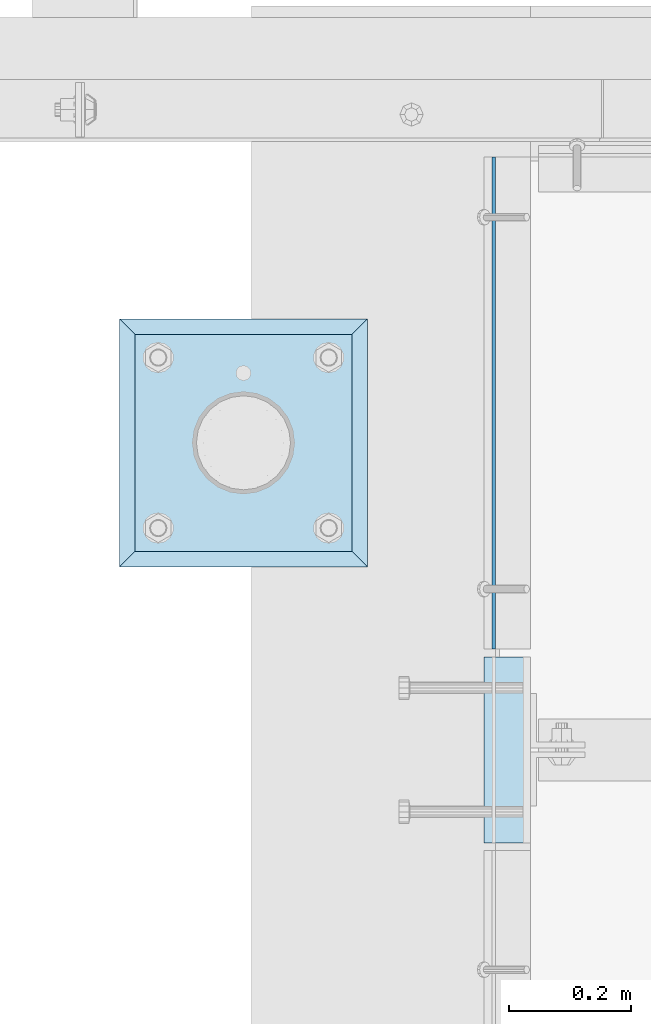
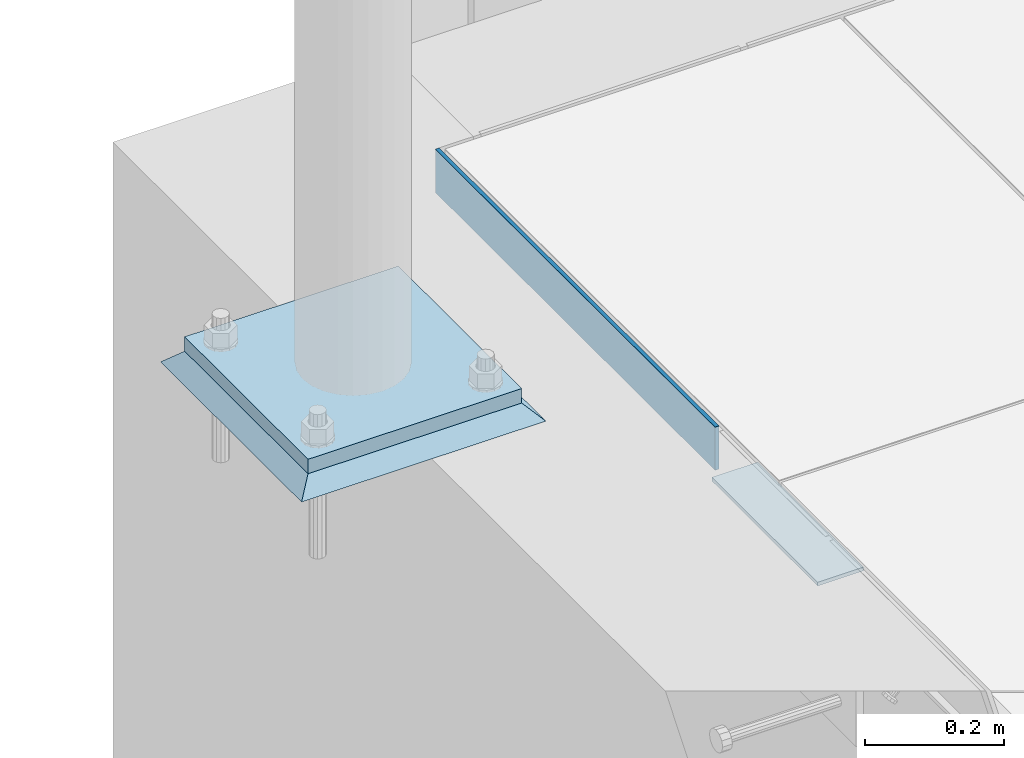
# One storey, part 3026 of 3843: 4 plates, 4 elements without a shape of their own.
"""IFC2X3 building model written with IfcOpenShell, lengths in millimetres."""

from ifc_helpers import new_model, si_unit, frame, origin_with_axes, place, context, subcontext, project, spatial, faceted_brep, material, type_object, element, aggregate, save


model = new_model("IFC2X3")

# Units and contexts
model_context = context("Model", 3, precision=1e-05, world=origin_with_axes())
body_context = subcontext(model_context, "Body", "Model", "MODEL_VIEW")
ifc_project = project(units=[si_unit("LENGTHUNIT", "METRE", prefix="MILLI"), si_unit("AREAUNIT", "SQUARE_METRE"), si_unit("VOLUMEUNIT", "CUBIC_METRE"), si_unit("MASSUNIT", "GRAM", prefix="KILO"), si_unit("TIMEUNIT", "SECOND"), si_unit("PLANEANGLEUNIT", "RADIAN"), si_unit("SOLIDANGLEUNIT", "STERADIAN"), si_unit("THERMODYNAMICTEMPERATUREUNIT", "DEGREE_CELSIUS"), si_unit("LUMINOUSINTENSITYUNIT", "LUMEN")], contexts=[model_context])

# Site, building, storey
site_placement = place(None, origin_with_axes())
site = spatial("IfcSite", under=ifc_project, at=site_placement, CompositionType="ELEMENT")
building_placement = place(site_placement, origin_with_axes())
building = spatial("IfcBuilding", under=site, at=building_placement, Name="Undefined", CompositionType="ELEMENT")
storey_placement = place(building_placement, origin_with_axes())
storey = spatial("IfcBuildingStorey", under=building, at=storey_placement, Name="Undefined", CompositionType="ELEMENT", Elevation=0.0)

# Assembly, plate
assembly_1_placement = place(storey_placement, origin_with_axes())
assembly_1 = element("IfcElementAssembly", 1, at=assembly_1_placement, inside=storey, Name="EMBED PLATE", AssemblyPlace="NOTDEFINED", PredefinedType="RIGID_FRAME")
ifc_material_1 = material(Name="STEEL/A36")
plate_type_1 = type_object("IfcPlateType", PredefinedType="NOTDEFINED")
plate_1_placement = place(assembly_1_placement, frame((41417.875, 24161.75, 30400.625), z_axis=(0.0, -1.0, 0.0), x_axis=(-1.0, 0.0, 0.0)))
plate_1 = element("IfcPlate", 2, at=plate_1_placement, type_object=plate_type_1, material=ifc_material_1, Name="PLATE", context=body_context, shape_type="Brep", body=[
    faceted_brep([(0.0, -3.17499999999927, 0.0), (0.0, -3.17499999999927, 304.800000000003), (0.0, 3.17499999999927, 304.800000000003), (0.0, 3.17499999999927, 0.0), (76.1999999999971, -3.17499999999927, 304.799999999996), (76.1999999999971, 3.17499999999927, 304.799999999996), (76.1999999999971, -3.17499999999927, 0.0), (76.1999999999971, 3.17499999999927, 0.0)], [[[0, 1, 2, 3]], [[1, 4, 5, 2]], [[4, 6, 7, 5]], [[6, 0, 3, 7]], [[5, 7, 3, 2]], [[6, 4, 1, 0]]]),
])
aggregate(assembly_1, [plate_1])

assembly_2_placement = place(storey_placement, origin_with_axes())
assembly_2 = element("IfcElementAssembly", 3, at=assembly_2_placement, inside=storey, Name="ANGLE", AssemblyPlace="NOTDEFINED", PredefinedType="RIGID_FRAME")
plate_2_placement = place(assembly_2_placement, frame((41357.5500030517, 24174.4498809285, 30403.8000030518), z_axis=(0.0, 0.999999999997942, -2.02899998962774e-06), x_axis=(0.0, 2.02899999567308e-06, 0.999999999997942)))
plate_2 = element("IfcPlate", 4, at=plate_2_placement, type_object=plate_type_1, material=ifc_material_1, Name="PLATE", context=body_context, shape_type="Brep", body=[
    faceted_brep([(0.0, -3.17499999999927, 0.0), (0.00108199702663114, -3.17500000000291, 806.450036627399), (0.00108199702663114, 3.17500000000291, 806.450036627399), (0.0, 3.17499999999927, 0.0), (76.2010812158915, -3.17500000000291, 806.449975592201), (76.2010812158915, 3.17500000000291, 806.449975592201), (76.1999999999971, -3.17499999999927, 0.0), (76.1999999999971, 3.17499999999927, 0.0)], [[[0, 1, 2, 3]], [[1, 4, 5, 2]], [[4, 6, 7, 5]], [[6, 0, 3, 7]], [[5, 7, 3, 2]], [[6, 4, 1, 0]]]),
])
aggregate(assembly_2, [plate_2])

assembly_3_placement = place(storey_placement, origin_with_axes())
assembly_3 = element("IfcElementAssembly", 5, at=assembly_3_placement, inside=storey, Name="PIPE_BOLLARD", AssemblyPlace="NOTDEFINED", PredefinedType="RIGID_FRAME")
ifc_material_2 = material(Name="STEEL/A572-50")
plate_type_2 = type_object("IfcPlateType", PredefinedType="NOTDEFINED")
plate_3_placement = place(assembly_3_placement, frame((40769.4793884277, 24334.8638262535, 30518.1), z_axis=(0.0, 1.0, 0.0), x_axis=(1.0, 0.0, 0.0)))
plate_3 = element("IfcPlate", 6, at=plate_3_placement, type_object=plate_type_2, material=ifc_material_2, Name="PLATE", context=body_context, shape_type="Brep", body=[
    faceted_brep([(0.0, -12.6999999999971, 0.0), (0.0, -12.7000000000007, 355.600000000006), (0.0, 12.7000000000007, 355.600000000006), (0.0, 12.6999999999971, 0.0), (355.599999999999, -12.7000000000007, 355.600000000006), (355.599999999999, 12.7000000000007, 355.600000000006), (355.599999999999, -12.7000000000007, 0.0), (355.599999999999, 12.7000000000007, 0.0)], [[[0, 1, 2, 3]], [[1, 4, 5, 2]], [[4, 6, 7, 5]], [[6, 0, 3, 7]], [[5, 7, 3, 2]], [[6, 4, 1, 0]]]),
])
aggregate(assembly_3, [plate_3])

assembly_4_placement = place(storey_placement, origin_with_axes())
assembly_4 = element("IfcElementAssembly", 7, at=assembly_4_placement, inside=storey, Name="GROUT", AssemblyPlace="NOTDEFINED", PredefinedType="REINFORCEMENT_UNIT")
ifc_material_3 = material(Name="CONCRETE/Concrete_Undefined")
plate_type_3 = type_object("IfcPlateType", PredefinedType="NOTDEFINED")
plate_4_placement = place(assembly_4_placement, frame((40744.0793884277, 24309.4638262535, 30492.7), z_axis=(0.0, 1.0, 0.0), x_axis=(1.0, 0.0, 0.0)))
plate_4 = element("IfcPlate", 8, at=plate_4_placement, type_object=plate_type_3, material=ifc_material_3, Name="GROUT", context=body_context, shape_type="Brep", body=[
    faceted_brep([(25.4000000001906, -12.6999999998552, 380.999999999505), (0.0, 12.7000000000007, 406.399999999994), (0.0, 12.6999999999971, 0.0), (25.4000000001906, -12.6999999999898, 25.4000000004453), (380.999999999833, -12.6999999998588, 25.4000000004453), (406.400000000001, 12.7000000000007, 0.0), (406.400000000001, 12.7000000000007, 406.399999999994), (380.999999999833, -12.6999999999898, 380.999999999505)], [[[0, 1, 2, 3]], [[4, 5, 6, 7]], [[4, 7, 0, 3]], [[5, 4, 3, 2]], [[6, 5, 2, 1]], [[7, 6, 1, 0]]]),
])
aggregate(assembly_4, [plate_4])

save(model, "model.ifc")
